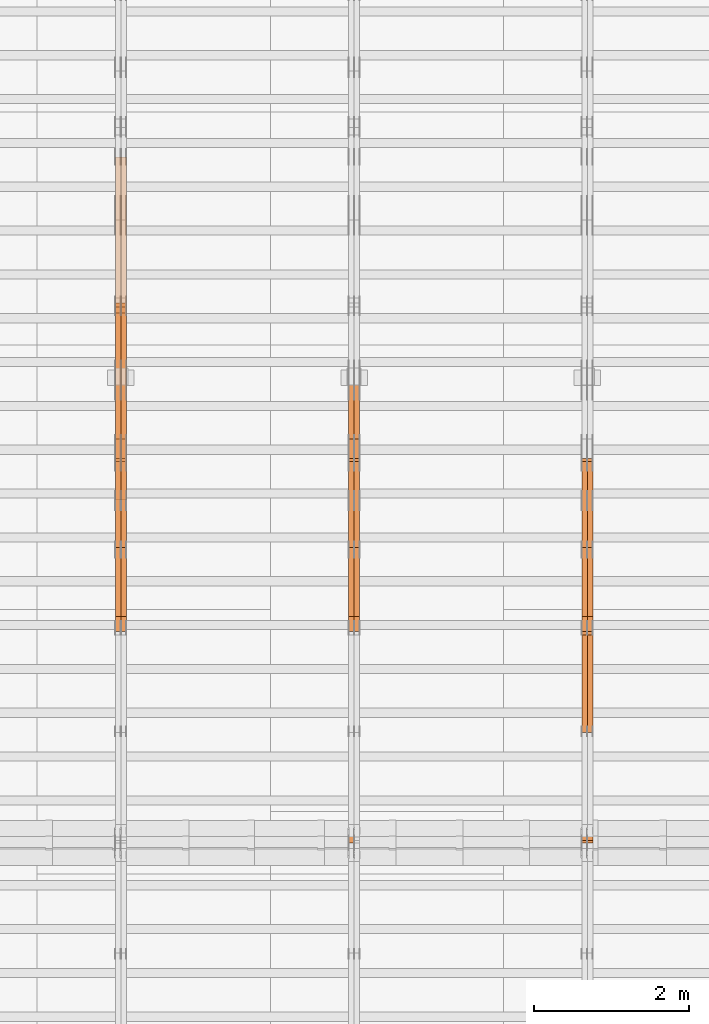
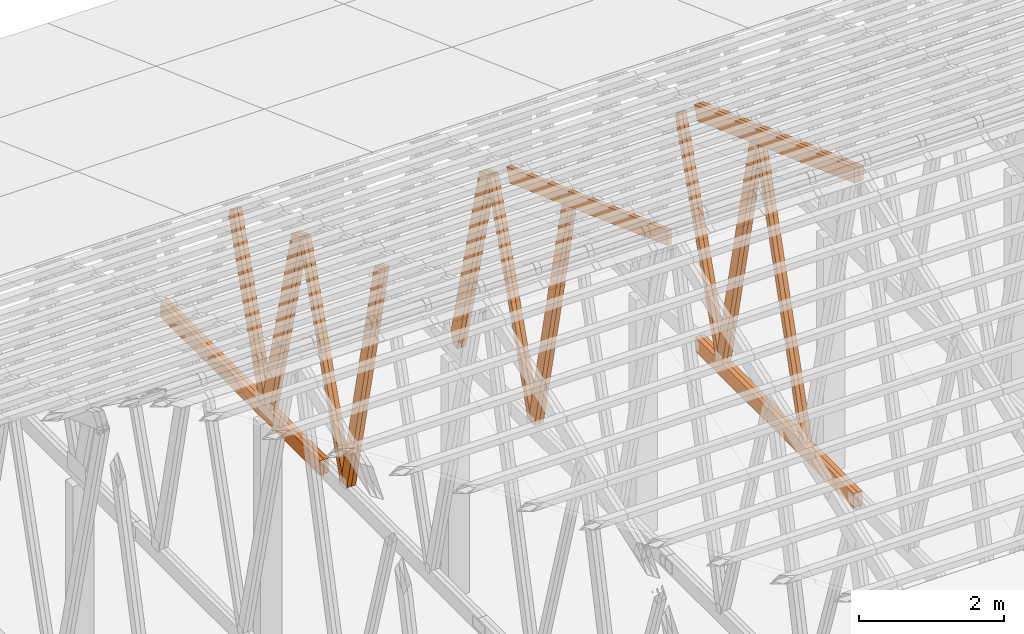
# One storey, part 38 of 189: 27 proxies.
"""IFC2X3 building model written with IfcOpenShell, lengths in millimetres."""

from ifc_helpers import new_model, entity, si_unit, converted_unit, derived_unit, direction, frame, origin, origin_2d_with_axis, place, context, subcontext, project, spatial, polyline, rectangle, outline, extrude, source, transform, mapped, material, type_object, type_shapes, element, save


model = new_model("IFC2X3")

# Units and contexts
model_context = context("Model", 3, precision=0.01, world=origin(), true_north=direction((6.12303176911189e-17, 1.0)))
body_context = subcontext(model_context, "Body", "Model", "MODEL_VIEW")
ifc_project = project(units=[si_unit("LENGTHUNIT", "METRE", prefix="MILLI"), si_unit("AREAUNIT", "SQUARE_METRE"), si_unit("VOLUMEUNIT", "CUBIC_METRE"), converted_unit("PLANEANGLEUNIT", "DEGREE", entity("IfcRatioMeasure", 0.0174532925199433), si_unit("PLANEANGLEUNIT", "RADIAN"), dimensions=[0, 0, 0, 0, 0, 0, 0]), si_unit("MASSUNIT", "GRAM", prefix="KILO"), derived_unit("MASSDENSITYUNIT", [(si_unit("MASSUNIT", "GRAM", prefix="KILO"), 1), (si_unit("LENGTHUNIT", "METRE"), -3)]), si_unit("TIMEUNIT", "SECOND"), si_unit("FREQUENCYUNIT", "HERTZ"), si_unit("THERMODYNAMICTEMPERATUREUNIT", "DEGREE_CELSIUS"), derived_unit("THERMALTRANSMITTANCEUNIT", [(si_unit("MASSUNIT", "GRAM", prefix="KILO"), 1), (si_unit("THERMODYNAMICTEMPERATUREUNIT", "KELVIN"), -1), (si_unit("TIMEUNIT", "SECOND"), -3)]), derived_unit("VOLUMETRICFLOWRATEUNIT", [(si_unit("LENGTHUNIT", "METRE"), 3), (si_unit("TIMEUNIT", "SECOND"), -1)]), si_unit("ELECTRICCURRENTUNIT", "AMPERE"), si_unit("ELECTRICVOLTAGEUNIT", "VOLT"), si_unit("POWERUNIT", "WATT"), si_unit("FORCEUNIT", "NEWTON"), si_unit("ILLUMINANCEUNIT", "LUX"), si_unit("LUMINOUSFLUXUNIT", "LUMEN"), si_unit("LUMINOUSINTENSITYUNIT", "CANDELA"), derived_unit("USERDEFINED", [(si_unit("MASSUNIT", "GRAM", prefix="KILO"), -1), (si_unit("LENGTHUNIT", "METRE"), -2), (si_unit("TIMEUNIT", "SECOND"), 3), (si_unit("LUMINOUSFLUXUNIT", "LUMEN"), 1)]), derived_unit("LINEARVELOCITYUNIT", [(si_unit("LENGTHUNIT", "METRE"), 1), (si_unit("TIMEUNIT", "SECOND"), -1)]), si_unit("PRESSUREUNIT", "PASCAL"), derived_unit("USERDEFINED", [(si_unit("LENGTHUNIT", "METRE"), -2), (si_unit("MASSUNIT", "GRAM", prefix="KILO"), 1), (si_unit("TIMEUNIT", "SECOND"), -2)])], contexts=[model_context])

# Site, building, storey
site_placement = place(None, origin())
site = spatial("IfcSite", under=ifc_project, at=site_placement, CompositionType="ELEMENT")
building_placement = place(site_placement, origin())
building = spatial("IfcBuilding", under=site, at=building_placement, CompositionType="ELEMENT")
storey_placement = place(building_placement, origin())
storey = spatial("IfcBuildingStorey", under=building, at=storey_placement, Name="Default", CompositionType="ELEMENT", Elevation=0.0)

# Proxies
ifc_material_1 = material(Name="IfcSurfaceStyle #115608")
building_element_proxy_type_1 = type_object("IfcBuildingElementProxyType", Name="T1-W6 115606", PredefinedType="NOTDEFINED", material=ifc_material_1)
shared_shape_1 = source(origin(), body_context, "Body", "SweptSolid", [
    extrude(outline(polyline([(-2668.68989660745, -47.5002238228721), (1800.72567700045, -47.5002238228721), (1797.68490303083, 0.000158637170537834), (1711.12272493628, 47.5001445042868), (-2640.84340836012, 47.5001445042868), (-2668.68989660745, -47.5002238228721)])), frame((1800.7257704503, 47.5001445042868, 0.0), z_axis=(0.0, 0.0, 1.0), x_axis=(-1.0, 0.0, 0.0)), (0.0, 0.0, 1.0), 69.9999999999997),
])
type_shapes(building_element_proxy_type_1, [shared_shape_1])
proxy_1_placement = place(building_placement, frame((21300.0, 17516.8749791841, 4507.23620831254), z_axis=(-1.0, 0.0, 0.0), x_axis=(0.0, -0.281285983104611, -0.959623986626466)))
element("IfcBuildingElementProxy", 1, at=proxy_1_placement, inside=storey, type_object=building_element_proxy_type_1, material=ifc_material_1, Name="T1-W6", context=body_context, shape_type="MappedRepresentation", body=[
    mapped(shared_shape_1, transform((0.0, 0.0, 0.0), scale=1.0)),
])
ifc_material_2 = material(Name="IfcSurfaceStyle #115542")
building_element_proxy_type_2 = type_object("IfcBuildingElementProxyType", Name="T1-W6 115540", PredefinedType="NOTDEFINED", material=ifc_material_2)
shared_shape_2 = source(origin(), body_context, "Body", "SweptSolid", [
    extrude(outline(polyline([(-2668.68989660745, -47.5002238228721), (1800.72567700045, -47.5002238228721), (1797.68490303083, 0.000158637170537834), (1711.12272493628, 47.5001445042868), (-2640.84340836012, 47.5001445042868), (-2668.68989660745, -47.5002238228721)])), frame((1800.7257704503, 47.5001445042868, 0.0), z_axis=(0.0, 0.0, 1.0), x_axis=(-1.0, 0.0, 0.0)), (0.0, 0.0, 1.0), 69.9999999999997),
])
type_shapes(building_element_proxy_type_2, [shared_shape_2])
proxy_2_placement = place(building_placement, frame((21230.0, 17516.8749791841, 4507.23620831254), z_axis=(-1.0, 0.0, 0.0), x_axis=(0.0, -0.281285983104611, -0.959623986626466)))
element("IfcBuildingElementProxy", 2, at=proxy_2_placement, inside=storey, type_object=building_element_proxy_type_2, material=ifc_material_2, Name="T1-W6", context=body_context, shape_type="MappedRepresentation", body=[
    mapped(shared_shape_2, transform((0.0, 0.0, 0.0), scale=1.0)),
])
ifc_material_3 = material(Name="IfcSurfaceStyle #115344")
building_element_proxy_type_3 = type_object("IfcBuildingElementProxyType", Name="T1-W3 115342", PredefinedType="NOTDEFINED", material=ifc_material_3)
shared_shape_3 = source(origin(), body_context, "Body", "SweptSolid", [
    extrude(outline(polyline([(-2517.58938959787, -85.0001104675026), (1625.445846867, -85.0001104675027), (1768.20563426494, 0.000209440697654673), (1749.48871563991, 85.0000057471538), (-2625.55080717397, 85.0000057471538), (-2517.58938959787, -85.0001104675026)])), frame((1768.2056683344, 85.0000547211315, 0.0), z_axis=(0.0, 0.0, 1.0), x_axis=(-1.0, 0.0, 0.0)), (0.0, 0.0, 1.0), 69.9999999999997),
])
type_shapes(building_element_proxy_type_3, [shared_shape_3])
proxy_3_placement = place(building_placement, frame((21300.0, 18415.3042863408, 226.720947016584), z_axis=(-1.0, 0.0, 0.0), x_axis=(0.0, -0.215047682154604, 0.976603550269982)))
element("IfcBuildingElementProxy", 3, at=proxy_3_placement, inside=storey, type_object=building_element_proxy_type_3, material=ifc_material_3, Name="T1-W3", context=body_context, shape_type="MappedRepresentation", body=[
    mapped(shared_shape_3, transform((0.0, 0.0, 0.0), scale=1.0)),
])
ifc_material_4 = material(Name="IfcSurfaceStyle #115278")
building_element_proxy_type_4 = type_object("IfcBuildingElementProxyType", Name="T1-W3 115276", PredefinedType="NOTDEFINED", material=ifc_material_4)
shared_shape_4 = source(origin(), body_context, "Body", "SweptSolid", [
    extrude(outline(polyline([(-2517.58938959787, -85.0001104675026), (1625.445846867, -85.0001104675027), (1768.20563426494, 0.000209440697654673), (1749.48871563991, 85.0000057471538), (-2625.55080717397, 85.0000057471538), (-2517.58938959787, -85.0001104675026)])), frame((1768.2056683344, 85.0000547211315, 0.0), z_axis=(0.0, 0.0, 1.0), x_axis=(-1.0, 0.0, 0.0)), (0.0, 0.0, 1.0), 69.9999999999997),
])
type_shapes(building_element_proxy_type_4, [shared_shape_4])
proxy_4_placement = place(building_placement, frame((21230.0, 18415.3042863408, 226.720947016584), z_axis=(-1.0, 0.0, 0.0), x_axis=(0.0, -0.215047682154604, 0.976603550269982)))
element("IfcBuildingElementProxy", 4, at=proxy_4_placement, inside=storey, type_object=building_element_proxy_type_4, material=ifc_material_4, Name="T1-W3", context=body_context, shape_type="MappedRepresentation", body=[
    mapped(shared_shape_4, transform((0.0, 0.0, 0.0), scale=1.0)),
])
ifc_material_5 = material(Name="IfcSurfaceStyle #115080")
building_element_proxy_type_5 = type_object("IfcBuildingElementProxyType", Name="T1-W7 115078", PredefinedType="NOTDEFINED", material=ifc_material_5)
shared_shape_5 = source(origin(), body_context, "Body", "SweptSolid", [
    extrude(outline(polyline([(-2189.6662270939, -47.5000140805343), (1475.30081553583, -47.5000140805343), (1473.93388518462, 0.00042343352179337), (1398.58463533215, 47.4998023637734), (-2158.15310895869, 47.4998023637734), (-2189.6662270939, -47.5000140805343)])), frame((1475.30081553583, 47.5004895824757, 0.0), z_axis=(0.0, 0.0, 1.0), x_axis=(-1.0, 0.0, 0.0)), (0.0, 0.0, 1.0), 69.9999999999998),
])
type_shapes(building_element_proxy_type_5, [shared_shape_5])
proxy_5_placement = place(building_placement, frame((21300.0, 19742.3819153401, 3693.66743808885), z_axis=(-1.0, 0.0, 0.0), x_axis=(0.0, -0.314845237923104, -0.949143021971475)))
element("IfcBuildingElementProxy", 5, at=proxy_5_placement, inside=storey, type_object=building_element_proxy_type_5, material=ifc_material_5, Name="T1-W7", context=body_context, shape_type="MappedRepresentation", body=[
    mapped(shared_shape_5, transform((0.0, 0.0, 0.0), scale=1.0)),
])
ifc_material_6 = material(Name="IfcSurfaceStyle #115014")
building_element_proxy_type_6 = type_object("IfcBuildingElementProxyType", Name="T1-W7 115012", PredefinedType="NOTDEFINED", material=ifc_material_6)
shared_shape_6 = source(origin(), body_context, "Body", "SweptSolid", [
    extrude(outline(polyline([(-2189.6662270939, -47.5000140805343), (1475.30081553583, -47.5000140805343), (1473.93388518462, 0.00042343352179337), (1398.58463533215, 47.4998023637734), (-2158.15310895869, 47.4998023637734), (-2189.6662270939, -47.5000140805343)])), frame((1475.30081553583, 47.5004895824757, 0.0), z_axis=(0.0, 0.0, 1.0), x_axis=(-1.0, 0.0, 0.0)), (0.0, 0.0, 1.0), 69.9999999999998),
])
type_shapes(building_element_proxy_type_6, [shared_shape_6])
proxy_6_placement = place(building_placement, frame((21230.0, 19742.3819153401, 3693.66743808885), z_axis=(-1.0, 0.0, 0.0), x_axis=(0.0, -0.314845237923104, -0.949143021971475)))
element("IfcBuildingElementProxy", 6, at=proxy_6_placement, inside=storey, type_object=building_element_proxy_type_6, material=ifc_material_6, Name="T1-W7", context=body_context, shape_type="MappedRepresentation", body=[
    mapped(shared_shape_6, transform((0.0, 0.0, 0.0), scale=1.0)),
])
ifc_material_7 = material(Name="IfcSurfaceStyle #111834")
building_element_proxy_type_7 = type_object("IfcBuildingElementProxyType", Name="T1-B5 111832", PredefinedType="NOTDEFINED", material=ifc_material_7)
shared_shape_7 = source(origin(), body_context, "Body", "SweptSolid", [
    extrude(rectangle(XDim=4381.5, YDim=245.000000000001, at=origin_2d_with_axis()), frame((2190.75, 122.5, 0.0), z_axis=(0.0, 0.0, 1.0), x_axis=(-1.0, 0.0, 0.0)), (0.0, 0.0, 1.0), 69.9999999999997),
])
type_shapes(building_element_proxy_type_7, [shared_shape_7])
proxy_7_placement = place(building_placement, frame((21300.0, 14780.2587890625, 245.0), z_axis=(-1.0, 0.0, 0.0), x_axis=(0.0, 1.0, 0.0)))
element("IfcBuildingElementProxy", 7, at=proxy_7_placement, inside=storey, type_object=building_element_proxy_type_7, material=ifc_material_7, Name="T1-B5", context=body_context, shape_type="MappedRepresentation", body=[
    mapped(shared_shape_7, transform((0.0, 0.0, 0.0), scale=1.0)),
])
ifc_material_8 = material(Name="IfcSurfaceStyle #111777")
building_element_proxy_type_8 = type_object("IfcBuildingElementProxyType", Name="T1-B5 111775", PredefinedType="NOTDEFINED", material=ifc_material_8)
shared_shape_8 = source(origin(), body_context, "Body", "SweptSolid", [
    extrude(rectangle(XDim=4381.5, YDim=245.000000000001, at=origin_2d_with_axis()), frame((2190.75, 122.5, 0.0), z_axis=(0.0, 0.0, 1.0), x_axis=(-1.0, 0.0, 0.0)), (0.0, 0.0, 1.0), 69.9999999999997),
])
type_shapes(building_element_proxy_type_8, [shared_shape_8])
proxy_8_placement = place(building_placement, frame((21230.0, 14780.2587890625, 245.0), z_axis=(-1.0, 0.0, 0.0), x_axis=(0.0, 1.0, 0.0)))
element("IfcBuildingElementProxy", 8, at=proxy_8_placement, inside=storey, type_object=building_element_proxy_type_8, material=ifc_material_8, Name="T1-B5", context=body_context, shape_type="MappedRepresentation", body=[
    mapped(shared_shape_8, transform((0.0, 0.0, 0.0), scale=1.0)),
])
ifc_material_9 = material(Name="IfcSurfaceStyle #111018")
building_element_proxy_type_9 = type_object("IfcBuildingElementProxyType", Name="T1-T3 111016", PredefinedType="NOTDEFINED", material=ifc_material_9)
shared_shape_9 = source(origin(), body_context, "Body", "SweptSolid", [
    extrude(outline(polyline([(-2386.23525922045, -122.500022994835), (2341.64890001386, -122.500022994835), (2341.64888416412, 122.500022994835), (-2297.06252495753, 122.500022994835), (-2386.23525922045, -122.500022994835)])), frame((2341.64890001386, 122.500051926629, 0.0), z_axis=(0.0, 0.0, 1.0), x_axis=(-1.0, 0.0, 0.0)), (0.0, 0.0, 1.0), 69.9999999999997),
])
type_shapes(building_element_proxy_type_9, [shared_shape_9])
proxy_9_placement = place(building_placement, frame((21300.0, 19108.9628956236, 3921.30465489208), z_axis=(-1.0, 0.0, 0.0), x_axis=(0.0, -0.939692620785908, 0.342020143325669)))
element("IfcBuildingElementProxy", 9, at=proxy_9_placement, inside=storey, type_object=building_element_proxy_type_9, material=ifc_material_9, Name="T1-T3", context=body_context, shape_type="MappedRepresentation", body=[
    mapped(shared_shape_9, transform((0.0, 0.0, 0.0), scale=1.0)),
])
ifc_material_10 = material(Name="IfcSurfaceStyle #110961")
building_element_proxy_type_10 = type_object("IfcBuildingElementProxyType", Name="T1-T3 110959", PredefinedType="NOTDEFINED", material=ifc_material_10)
shared_shape_10 = source(origin(), body_context, "Body", "SweptSolid", [
    extrude(outline(polyline([(-2386.23525922045, -122.500022994835), (2341.64890001386, -122.500022994835), (2341.64888416412, 122.500022994835), (-2297.06252495753, 122.500022994835), (-2386.23525922045, -122.500022994835)])), frame((2341.64890001386, 122.500051926629, 0.0), z_axis=(0.0, 0.0, 1.0), x_axis=(-1.0, 0.0, 0.0)), (0.0, 0.0, 1.0), 69.9999999999997),
])
type_shapes(building_element_proxy_type_10, [shared_shape_10])
proxy_10_placement = place(building_placement, frame((21230.0, 19108.9628956236, 3921.30465489208), z_axis=(-1.0, 0.0, 0.0), x_axis=(0.0, -0.939692620785908, 0.342020143325669)))
element("IfcBuildingElementProxy", 10, at=proxy_10_placement, inside=storey, type_object=building_element_proxy_type_10, material=ifc_material_10, Name="T1-T3", context=body_context, shape_type="MappedRepresentation", body=[
    mapped(shared_shape_10, transform((0.0, 0.0, 0.0), scale=1.0)),
])
ifc_material_11 = material(Name="IfcSurfaceStyle #99554")
building_element_proxy_type_11 = type_object("IfcBuildingElementProxyType", Name="T1-W3 99552", PredefinedType="NOTDEFINED", material=ifc_material_11)
shared_shape_11 = source(origin(), body_context, "Body", "SweptSolid", [
    extrude(outline(polyline([(-2517.58938959787, -85.0001104675026), (1625.445846867, -85.0001104675027), (1768.20563426494, 0.000209440697654673), (1749.48871563991, 85.0000057471538), (-2625.55080717397, 85.0000057471538), (-2517.58938959787, -85.0001104675026)])), frame((1768.2056683344, 85.0000547211315, 0.0), z_axis=(0.0, 0.0, 1.0), x_axis=(-1.0, 0.0, 0.0)), (0.0, 0.0, 1.0), 69.9999999999997),
])
type_shapes(building_element_proxy_type_11, [shared_shape_11])
proxy_11_placement = place(building_placement, frame((18300.0, 18415.3042863408, 226.720947016584), z_axis=(-1.0, 0.0, 0.0), x_axis=(0.0, -0.215047682154604, 0.976603550269982)))
element("IfcBuildingElementProxy", 11, at=proxy_11_placement, inside=storey, type_object=building_element_proxy_type_11, material=ifc_material_11, Name="T1-W3", context=body_context, shape_type="MappedRepresentation", body=[
    mapped(shared_shape_11, transform((0.0, 0.0, 0.0), scale=1.0)),
])
ifc_material_12 = material(Name="IfcSurfaceStyle #99488")
building_element_proxy_type_12 = type_object("IfcBuildingElementProxyType", Name="T1-W3 99486", PredefinedType="NOTDEFINED", material=ifc_material_12)
shared_shape_12 = source(origin(), body_context, "Body", "SweptSolid", [
    extrude(outline(polyline([(-2517.58938959787, -85.0001104675026), (1625.445846867, -85.0001104675027), (1768.20563426494, 0.000209440697654673), (1749.48871563991, 85.0000057471538), (-2625.55080717397, 85.0000057471538), (-2517.58938959787, -85.0001104675026)])), frame((1768.2056683344, 85.0000547211315, 0.0), z_axis=(0.0, 0.0, 1.0), x_axis=(-1.0, 0.0, 0.0)), (0.0, 0.0, 1.0), 69.9999999999997),
])
type_shapes(building_element_proxy_type_12, [shared_shape_12])
proxy_12_placement = place(building_placement, frame((18230.0, 18415.3042863408, 226.720947016584), z_axis=(-1.0, 0.0, 0.0), x_axis=(0.0, -0.215047682154604, 0.976603550269982)))
element("IfcBuildingElementProxy", 12, at=proxy_12_placement, inside=storey, type_object=building_element_proxy_type_12, material=ifc_material_12, Name="T1-W3", context=body_context, shape_type="MappedRepresentation", body=[
    mapped(shared_shape_12, transform((0.0, 0.0, 0.0), scale=1.0)),
])
ifc_material_13 = material(Name="IfcSurfaceStyle #99290")
building_element_proxy_type_13 = type_object("IfcBuildingElementProxyType", Name="T1-W7 99288", PredefinedType="NOTDEFINED", material=ifc_material_13)
shared_shape_13 = source(origin(), body_context, "Body", "SweptSolid", [
    extrude(outline(polyline([(-2189.6662270939, -47.5000140805343), (1475.30081553583, -47.5000140805343), (1473.93388518462, 0.00042343352179337), (1398.58463533215, 47.4998023637734), (-2158.15310895869, 47.4998023637734), (-2189.6662270939, -47.5000140805343)])), frame((1475.30081553583, 47.5004895824757, 0.0), z_axis=(0.0, 0.0, 1.0), x_axis=(-1.0, 0.0, 0.0)), (0.0, 0.0, 1.0), 69.9999999999998),
])
type_shapes(building_element_proxy_type_13, [shared_shape_13])
proxy_13_placement = place(building_placement, frame((18300.0, 19742.3819153401, 3693.66743808885), z_axis=(-1.0, 0.0, 0.0), x_axis=(0.0, -0.314845237923104, -0.949143021971475)))
element("IfcBuildingElementProxy", 13, at=proxy_13_placement, inside=storey, type_object=building_element_proxy_type_13, material=ifc_material_13, Name="T1-W7", context=body_context, shape_type="MappedRepresentation", body=[
    mapped(shared_shape_13, transform((0.0, 0.0, 0.0), scale=1.0)),
])
ifc_material_14 = material(Name="IfcSurfaceStyle #99224")
building_element_proxy_type_14 = type_object("IfcBuildingElementProxyType", Name="T1-W7 99222", PredefinedType="NOTDEFINED", material=ifc_material_14)
shared_shape_14 = source(origin(), body_context, "Body", "SweptSolid", [
    extrude(outline(polyline([(-2189.6662270939, -47.5000140805343), (1475.30081553583, -47.5000140805343), (1473.93388518462, 0.00042343352179337), (1398.58463533215, 47.4998023637734), (-2158.15310895869, 47.4998023637734), (-2189.6662270939, -47.5000140805343)])), frame((1475.30081553583, 47.5004895824757, 0.0), z_axis=(0.0, 0.0, 1.0), x_axis=(-1.0, 0.0, 0.0)), (0.0, 0.0, 1.0), 69.9999999999998),
])
type_shapes(building_element_proxy_type_14, [shared_shape_14])
proxy_14_placement = place(building_placement, frame((18230.0, 19742.3819153401, 3693.66743808885), z_axis=(-1.0, 0.0, 0.0), x_axis=(0.0, -0.314845237923104, -0.949143021971475)))
element("IfcBuildingElementProxy", 14, at=proxy_14_placement, inside=storey, type_object=building_element_proxy_type_14, material=ifc_material_14, Name="T1-W7", context=body_context, shape_type="MappedRepresentation", body=[
    mapped(shared_shape_14, transform((0.0, 0.0, 0.0), scale=1.0)),
])
ifc_material_15 = material(Name="IfcSurfaceStyle #99026")
building_element_proxy_type_15 = type_object("IfcBuildingElementProxyType", Name="T1-W1 99024", PredefinedType="NOTDEFINED", material=ifc_material_15)
shared_shape_15 = source(origin(), body_context, "Body", "SweptSolid", [
    extrude(outline(polyline([(-1996.99427801396, -109.999889649051), (1271.09905152223, -109.999889649051), (1448.88120817726, -0.000113190727324008), (1421.70802776002, 109.999946244415), (-2144.69400944554, 109.999946244415), (-1996.99427801396, -109.999889649051)])), frame((1448.88120817726, 110.000265670598, 0.0), z_axis=(0.0, 0.0, 1.0), x_axis=(-1.0, 0.0, 0.0)), (0.0, 0.0, 1.0), 69.9999999999998),
])
type_shapes(building_element_proxy_type_15, [shared_shape_15])
proxy_15_placement = place(building_placement, frame((18300.0, 20558.6774904859, 218.61972674968), z_axis=(-1.0, 0.0, 0.0), x_axis=(0.0, -0.239819839925979, 0.970817410421691)))
element("IfcBuildingElementProxy", 15, at=proxy_15_placement, inside=storey, type_object=building_element_proxy_type_15, material=ifc_material_15, Name="T1-W1", context=body_context, shape_type="MappedRepresentation", body=[
    mapped(shared_shape_15, transform((0.0, 0.0, 0.0), scale=1.0)),
])
ifc_material_16 = material(Name="IfcSurfaceStyle #98960")
building_element_proxy_type_16 = type_object("IfcBuildingElementProxyType", Name="T1-W1 98958", PredefinedType="NOTDEFINED", material=ifc_material_16)
shared_shape_16 = source(origin(), body_context, "Body", "SweptSolid", [
    extrude(outline(polyline([(-1996.99427801396, -109.999889649051), (1271.09905152223, -109.999889649051), (1448.88120817726, -0.000113190727324008), (1421.70802776002, 109.999946244415), (-2144.69400944554, 109.999946244415), (-1996.99427801396, -109.999889649051)])), frame((1448.88120817726, 110.000265670598, 0.0), z_axis=(0.0, 0.0, 1.0), x_axis=(-1.0, 0.0, 0.0)), (0.0, 0.0, 1.0), 69.9999999999998),
])
type_shapes(building_element_proxy_type_16, [shared_shape_16])
proxy_16_placement = place(building_placement, frame((18230.0, 20558.6774904859, 218.61972674968), z_axis=(-1.0, 0.0, 0.0), x_axis=(0.0, -0.239819839925979, 0.970817410421691)))
element("IfcBuildingElementProxy", 16, at=proxy_16_placement, inside=storey, type_object=building_element_proxy_type_16, material=ifc_material_16, Name="T1-W1", context=body_context, shape_type="MappedRepresentation", body=[
    mapped(shared_shape_16, transform((0.0, 0.0, 0.0), scale=1.0)),
])
ifc_material_17 = material(Name="IfcSurfaceStyle #95171")
building_element_proxy_type_17 = type_object("IfcBuildingElementProxyType", Name="T1-T3 95169", PredefinedType="NOTDEFINED", material=ifc_material_17)
shared_shape_17 = source(origin(), body_context, "Body", "SweptSolid", [
    extrude(outline(polyline([(-2386.23525922045, -122.500022994835), (2341.64890001386, -122.500022994835), (2341.64888416412, 122.500022994835), (-2297.06252495753, 122.500022994835), (-2386.23525922045, -122.500022994835)])), frame((2341.64890001386, 122.500051926629, 0.0), z_axis=(0.0, 0.0, 1.0), x_axis=(-1.0, 0.0, 0.0)), (0.0, 0.0, 1.0), 69.9999999999997),
])
type_shapes(building_element_proxy_type_17, [shared_shape_17])
proxy_17_placement = place(building_placement, frame((18230.0, 19108.9628956236, 3921.30465489208), z_axis=(-1.0, 0.0, 0.0), x_axis=(0.0, -0.939692620785908, 0.342020143325669)))
element("IfcBuildingElementProxy", 17, at=proxy_17_placement, inside=storey, type_object=building_element_proxy_type_17, material=ifc_material_17, Name="T1-T3", context=body_context, shape_type="MappedRepresentation", body=[
    mapped(shared_shape_17, transform((0.0, 0.0, 0.0), scale=1.0)),
])
ifc_material_18 = material(Name="IfcSurfaceStyle #83764")
building_element_proxy_type_18 = type_object("IfcBuildingElementProxyType", Name="T1-W3 83762", PredefinedType="NOTDEFINED", material=ifc_material_18)
shared_shape_18 = source(origin(), body_context, "Body", "SweptSolid", [
    extrude(outline(polyline([(-2517.58938959787, -85.0001104675026), (1625.445846867, -85.0001104675027), (1768.20563426494, 0.000209440697654673), (1749.48871563991, 85.0000057471538), (-2625.55080717397, 85.0000057471538), (-2517.58938959787, -85.0001104675026)])), frame((1768.2056683344, 85.0000547211315, 0.0), z_axis=(0.0, 0.0, 1.0), x_axis=(-1.0, 0.0, 0.0)), (0.0, 0.0, 1.0), 69.9999999999997),
])
type_shapes(building_element_proxy_type_18, [shared_shape_18])
proxy_18_placement = place(building_placement, frame((15300.0, 18415.3042863408, 226.720947016584), z_axis=(-1.0, 0.0, 0.0), x_axis=(0.0, -0.215047682154604, 0.976603550269982)))
element("IfcBuildingElementProxy", 18, at=proxy_18_placement, inside=storey, type_object=building_element_proxy_type_18, material=ifc_material_18, Name="T1-W3", context=body_context, shape_type="MappedRepresentation", body=[
    mapped(shared_shape_18, transform((0.0, 0.0, 0.0), scale=1.0)),
])
ifc_material_19 = material(Name="IfcSurfaceStyle #83698")
building_element_proxy_type_19 = type_object("IfcBuildingElementProxyType", Name="T1-W3 83696", PredefinedType="NOTDEFINED", material=ifc_material_19)
shared_shape_19 = source(origin(), body_context, "Body", "SweptSolid", [
    extrude(outline(polyline([(-2517.58938959787, -85.0001104675026), (1625.445846867, -85.0001104675027), (1768.20563426494, 0.000209440697654673), (1749.48871563991, 85.0000057471538), (-2625.55080717397, 85.0000057471538), (-2517.58938959787, -85.0001104675026)])), frame((1768.2056683344, 85.0000547211315, 0.0), z_axis=(0.0, 0.0, 1.0), x_axis=(-1.0, 0.0, 0.0)), (0.0, 0.0, 1.0), 69.9999999999997),
])
type_shapes(building_element_proxy_type_19, [shared_shape_19])
proxy_19_placement = place(building_placement, frame((15230.0, 18415.3042863408, 226.720947016584), z_axis=(-1.0, 0.0, 0.0), x_axis=(0.0, -0.215047682154604, 0.976603550269982)))
element("IfcBuildingElementProxy", 19, at=proxy_19_placement, inside=storey, type_object=building_element_proxy_type_19, material=ifc_material_19, Name="T1-W3", context=body_context, shape_type="MappedRepresentation", body=[
    mapped(shared_shape_19, transform((0.0, 0.0, 0.0), scale=1.0)),
])
ifc_material_20 = material(Name="IfcSurfaceStyle #83500")
building_element_proxy_type_20 = type_object("IfcBuildingElementProxyType", Name="T1-W7 83498", PredefinedType="NOTDEFINED", material=ifc_material_20)
shared_shape_20 = source(origin(), body_context, "Body", "SweptSolid", [
    extrude(outline(polyline([(-2189.6662270939, -47.5000140805343), (1475.30081553583, -47.5000140805343), (1473.93388518462, 0.00042343352179337), (1398.58463533215, 47.4998023637734), (-2158.15310895869, 47.4998023637734), (-2189.6662270939, -47.5000140805343)])), frame((1475.30081553583, 47.5004895824757, 0.0), z_axis=(0.0, 0.0, 1.0), x_axis=(-1.0, 0.0, 0.0)), (0.0, 0.0, 1.0), 69.9999999999998),
])
type_shapes(building_element_proxy_type_20, [shared_shape_20])
proxy_20_placement = place(building_placement, frame((15300.0, 19742.3819153401, 3693.66743808885), z_axis=(-1.0, 0.0, 0.0), x_axis=(0.0, -0.314845237923104, -0.949143021971475)))
element("IfcBuildingElementProxy", 20, at=proxy_20_placement, inside=storey, type_object=building_element_proxy_type_20, material=ifc_material_20, Name="T1-W7", context=body_context, shape_type="MappedRepresentation", body=[
    mapped(shared_shape_20, transform((0.0, 0.0, 0.0), scale=1.0)),
])
ifc_material_21 = material(Name="IfcSurfaceStyle #83434")
building_element_proxy_type_21 = type_object("IfcBuildingElementProxyType", Name="T1-W7 83432", PredefinedType="NOTDEFINED", material=ifc_material_21)
shared_shape_21 = source(origin(), body_context, "Body", "SweptSolid", [
    extrude(outline(polyline([(-2189.6662270939, -47.5000140805343), (1475.30081553583, -47.5000140805343), (1473.93388518462, 0.00042343352179337), (1398.58463533215, 47.4998023637734), (-2158.15310895869, 47.4998023637734), (-2189.6662270939, -47.5000140805343)])), frame((1475.30081553583, 47.5004895824757, 0.0), z_axis=(0.0, 0.0, 1.0), x_axis=(-1.0, 0.0, 0.0)), (0.0, 0.0, 1.0), 69.9999999999998),
])
type_shapes(building_element_proxy_type_21, [shared_shape_21])
proxy_21_placement = place(building_placement, frame((15230.0, 19742.3819153401, 3693.66743808885), z_axis=(-1.0, 0.0, 0.0), x_axis=(0.0, -0.314845237923104, -0.949143021971475)))
element("IfcBuildingElementProxy", 21, at=proxy_21_placement, inside=storey, type_object=building_element_proxy_type_21, material=ifc_material_21, Name="T1-W7", context=body_context, shape_type="MappedRepresentation", body=[
    mapped(shared_shape_21, transform((0.0, 0.0, 0.0), scale=1.0)),
])
ifc_material_22 = material(Name="IfcSurfaceStyle #83236")
building_element_proxy_type_22 = type_object("IfcBuildingElementProxyType", Name="T1-W1 83234", PredefinedType="NOTDEFINED", material=ifc_material_22)
shared_shape_22 = source(origin(), body_context, "Body", "SweptSolid", [
    extrude(outline(polyline([(-1996.99427801396, -109.999889649051), (1271.09905152223, -109.999889649051), (1448.88120817726, -0.000113190727324008), (1421.70802776002, 109.999946244415), (-2144.69400944554, 109.999946244415), (-1996.99427801396, -109.999889649051)])), frame((1448.88120817726, 110.000265670598, 0.0), z_axis=(0.0, 0.0, 1.0), x_axis=(-1.0, 0.0, 0.0)), (0.0, 0.0, 1.0), 69.9999999999998),
])
type_shapes(building_element_proxy_type_22, [shared_shape_22])
proxy_22_placement = place(building_placement, frame((15300.0, 20558.6774904859, 218.61972674968), z_axis=(-1.0, 0.0, 0.0), x_axis=(0.0, -0.239819839925979, 0.970817410421691)))
element("IfcBuildingElementProxy", 22, at=proxy_22_placement, inside=storey, type_object=building_element_proxy_type_22, material=ifc_material_22, Name="T1-W1", context=body_context, shape_type="MappedRepresentation", body=[
    mapped(shared_shape_22, transform((0.0, 0.0, 0.0), scale=1.0)),
])
ifc_material_23 = material(Name="IfcSurfaceStyle #83170")
building_element_proxy_type_23 = type_object("IfcBuildingElementProxyType", Name="T1-W1 83168", PredefinedType="NOTDEFINED", material=ifc_material_23)
shared_shape_23 = source(origin(), body_context, "Body", "SweptSolid", [
    extrude(outline(polyline([(-1996.99427801396, -109.999889649051), (1271.09905152223, -109.999889649051), (1448.88120817726, -0.000113190727324008), (1421.70802776002, 109.999946244415), (-2144.69400944554, 109.999946244415), (-1996.99427801396, -109.999889649051)])), frame((1448.88120817726, 110.000265670598, 0.0), z_axis=(0.0, 0.0, 1.0), x_axis=(-1.0, 0.0, 0.0)), (0.0, 0.0, 1.0), 69.9999999999998),
])
type_shapes(building_element_proxy_type_23, [shared_shape_23])
proxy_23_placement = place(building_placement, frame((15230.0, 20558.6774904859, 218.61972674968), z_axis=(-1.0, 0.0, 0.0), x_axis=(0.0, -0.239819839925979, 0.970817410421691)))
element("IfcBuildingElementProxy", 23, at=proxy_23_placement, inside=storey, type_object=building_element_proxy_type_23, material=ifc_material_23, Name="T1-W1", context=body_context, shape_type="MappedRepresentation", body=[
    mapped(shared_shape_23, transform((0.0, 0.0, 0.0), scale=1.0)),
])
ifc_material_24 = material(Name="IfcSurfaceStyle #82972")
building_element_proxy_type_24 = type_object("IfcBuildingElementProxyType", Name="T1-W4 82970", PredefinedType="NOTDEFINED", material=ifc_material_24)
shared_shape_24 = source(origin(), body_context, "Body", "SweptSolid", [
    extrude(outline(polyline([(-1742.90513395849, -84.9997422414737), (1181.3544167489, -84.9997422414737), (1178.19398821251, -0.000208932978430543), (1071.44989130457, 84.999846707963), (-1688.09316230749, 84.999846707963), (-1742.90513395849, -84.9997422414737)])), frame((1181.35452116422, 84.999886337523, 0.0), z_axis=(0.0, 0.0, 1.0), x_axis=(-1.0, 0.0, 0.0)), (0.0, 0.0, 1.0), 69.9999999999998),
])
type_shapes(building_element_proxy_type_24, [shared_shape_24])
proxy_24_placement = place(building_placement, frame((15300.0, 21724.6281517871, 2976.00232464744), z_axis=(-1.0, 0.0, 0.0), x_axis=(0.0, -0.306868406216495, -0.951751953644514)))
element("IfcBuildingElementProxy", 24, at=proxy_24_placement, inside=storey, type_object=building_element_proxy_type_24, material=ifc_material_24, Name="T1-W4", context=body_context, shape_type="MappedRepresentation", body=[
    mapped(shared_shape_24, transform((0.0, 0.0, 0.0), scale=1.0)),
])
ifc_material_25 = material(Name="IfcSurfaceStyle #82906")
building_element_proxy_type_25 = type_object("IfcBuildingElementProxyType", Name="T1-W4 82904", PredefinedType="NOTDEFINED", material=ifc_material_25)
shared_shape_25 = source(origin(), body_context, "Body", "SweptSolid", [
    extrude(outline(polyline([(-1742.90513395849, -84.9997422414737), (1181.3544167489, -84.9997422414737), (1178.19398821251, -0.000208932978430543), (1071.44989130457, 84.999846707963), (-1688.09316230749, 84.999846707963), (-1742.90513395849, -84.9997422414737)])), frame((1181.35452116422, 84.999886337523, 0.0), z_axis=(0.0, 0.0, 1.0), x_axis=(-1.0, 0.0, 0.0)), (0.0, 0.0, 1.0), 69.9999999999998),
])
type_shapes(building_element_proxy_type_25, [shared_shape_25])
proxy_25_placement = place(building_placement, frame((15230.0, 21724.6281517871, 2976.00232464744), z_axis=(-1.0, 0.0, 0.0), x_axis=(0.0, -0.306868406216495, -0.951751953644514)))
element("IfcBuildingElementProxy", 25, at=proxy_25_placement, inside=storey, type_object=building_element_proxy_type_25, material=ifc_material_25, Name="T1-W4", context=body_context, shape_type="MappedRepresentation", body=[
    mapped(shared_shape_25, transform((0.0, 0.0, 0.0), scale=1.0)),
])
ifc_material_26 = material(Name="IfcSurfaceStyle #80368")
building_element_proxy_type_26 = type_object("IfcBuildingElementProxyType", Name="T1-B4 80366", PredefinedType="NOTDEFINED", material=ifc_material_26)
shared_shape_26 = source(origin(), body_context, "Body", "SweptSolid", [
    extrude(rectangle(XDim=4408.2412109375, YDim=245.000000000001, at=origin_2d_with_axis()), frame((2204.12060546875, 122.5, 0.0), z_axis=(0.0, 0.0, 1.0), x_axis=(-1.0, 0.0, 0.0)), (0.0, 0.0, 1.0), 69.9999999999997),
])
type_shapes(building_element_proxy_type_26, [shared_shape_26])
proxy_26_placement = place(building_placement, frame((15300.0, 19161.7587890625, 245.0), z_axis=(-1.0, 0.0, 0.0), x_axis=(0.0, 1.0, 0.0)))
element("IfcBuildingElementProxy", 26, at=proxy_26_placement, inside=storey, type_object=building_element_proxy_type_26, material=ifc_material_26, Name="T1-B4", context=body_context, shape_type="MappedRepresentation", body=[
    mapped(shared_shape_26, transform((0.0, 0.0, 0.0), scale=1.0)),
])
ifc_material_27 = material(Name="IfcSurfaceStyle #80311")
building_element_proxy_type_27 = type_object("IfcBuildingElementProxyType", Name="T1-B4 80309", PredefinedType="NOTDEFINED", material=ifc_material_27)
shared_shape_27 = source(origin(), body_context, "Body", "SweptSolid", [
    extrude(rectangle(XDim=4408.2412109375, YDim=245.000000000001, at=origin_2d_with_axis()), frame((2204.12060546875, 122.5, 0.0), z_axis=(0.0, 0.0, 1.0), x_axis=(-1.0, 0.0, 0.0)), (0.0, 0.0, 1.0), 69.9999999999997),
])
type_shapes(building_element_proxy_type_27, [shared_shape_27])
proxy_27_placement = place(building_placement, frame((15230.0, 19161.7587890625, 245.0), z_axis=(-1.0, 0.0, 0.0), x_axis=(0.0, 1.0, 0.0)))
element("IfcBuildingElementProxy", 27, at=proxy_27_placement, inside=storey, type_object=building_element_proxy_type_27, material=ifc_material_27, Name="T1-B4", context=body_context, shape_type="MappedRepresentation", body=[
    mapped(shared_shape_27, transform((0.0, 0.0, 0.0), scale=1.0)),
])

save(model, "model.ifc")
